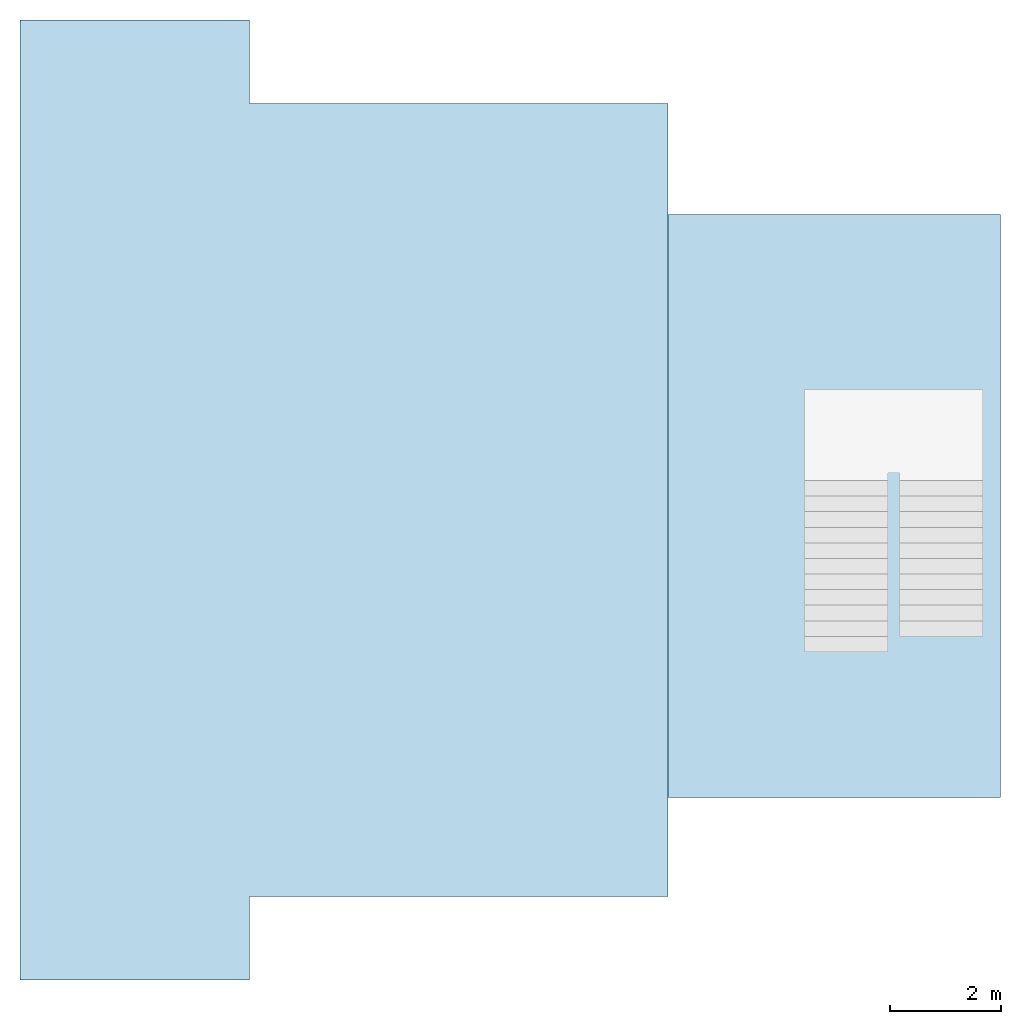
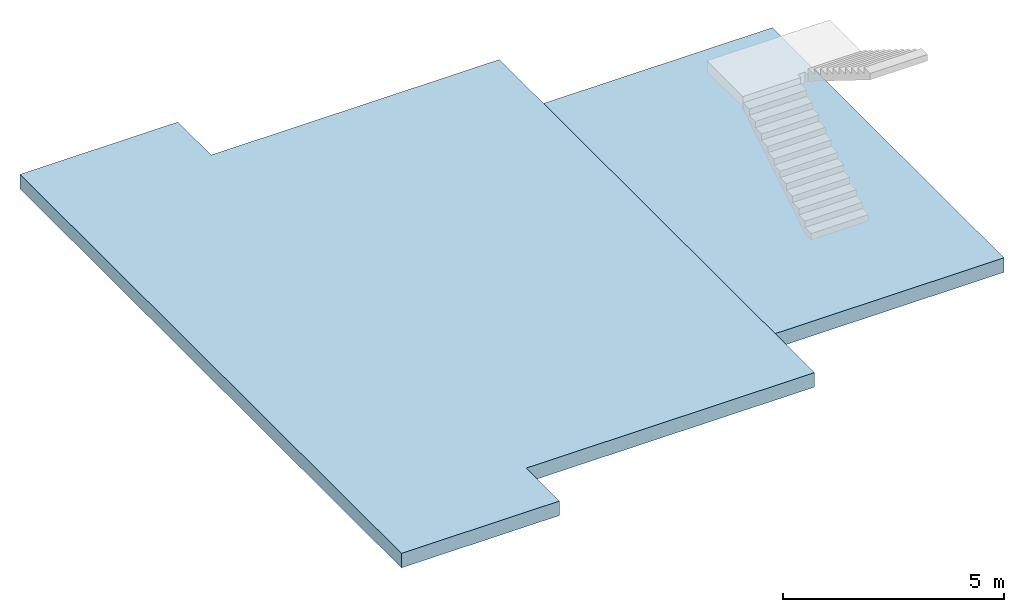
# One storey, part 1 of 2: 2 slabs.
"""IFC2X3 building model written with IfcOpenShell, lengths in millimetres."""

from ifc_helpers import new_model, entity, si_unit, converted_unit, derived_unit, direction, frame, origin, origin_2d_with_axis, place, context, subcontext, project, spatial, polyline, rectangle, outline, extrude, material, layer, layer_set, layer_usage, type_object, element, save


model = new_model("IFC2X3")

# Units and contexts
model_context = context("Model", 3, precision=0.01, world=origin(), true_north=direction((6.12303176911189e-17, 1.0)))
body_context = subcontext(model_context, "Body", "Model", "MODEL_VIEW")
ifc_project = project(units=[si_unit("LENGTHUNIT", "METRE", prefix="MILLI"), si_unit("AREAUNIT", "SQUARE_METRE"), si_unit("VOLUMEUNIT", "CUBIC_METRE"), converted_unit("PLANEANGLEUNIT", "DEGREE", entity("IfcRatioMeasure", 0.0174532925199433), si_unit("PLANEANGLEUNIT", "RADIAN"), dimensions=[0, 0, 0, 0, 0, 0, 0]), si_unit("MASSUNIT", "GRAM", prefix="KILO"), derived_unit("MASSDENSITYUNIT", [(si_unit("MASSUNIT", "GRAM", prefix="KILO"), 1), (si_unit("LENGTHUNIT", "METRE"), -3)]), si_unit("TIMEUNIT", "SECOND"), si_unit("FREQUENCYUNIT", "HERTZ"), si_unit("THERMODYNAMICTEMPERATUREUNIT", "DEGREE_CELSIUS"), derived_unit("THERMALTRANSMITTANCEUNIT", [(si_unit("MASSUNIT", "GRAM", prefix="KILO"), 1), (si_unit("THERMODYNAMICTEMPERATUREUNIT", "KELVIN"), -1), (si_unit("TIMEUNIT", "SECOND"), -3)]), derived_unit("VOLUMETRICFLOWRATEUNIT", [(si_unit("LENGTHUNIT", "METRE"), 3), (si_unit("TIMEUNIT", "SECOND"), -1)]), si_unit("ELECTRICCURRENTUNIT", "AMPERE"), si_unit("ELECTRICVOLTAGEUNIT", "VOLT"), si_unit("POWERUNIT", "WATT"), si_unit("FORCEUNIT", "NEWTON", prefix="KILO"), si_unit("ILLUMINANCEUNIT", "LUX"), si_unit("LUMINOUSFLUXUNIT", "LUMEN"), si_unit("LUMINOUSINTENSITYUNIT", "CANDELA"), derived_unit("USERDEFINED", [(si_unit("MASSUNIT", "GRAM", prefix="KILO"), -1), (si_unit("LENGTHUNIT", "METRE"), -2), (si_unit("TIMEUNIT", "SECOND"), 3), (si_unit("LUMINOUSFLUXUNIT", "LUMEN"), 1)]), derived_unit("LINEARVELOCITYUNIT", [(si_unit("LENGTHUNIT", "METRE"), 1), (si_unit("TIMEUNIT", "SECOND"), -1)]), si_unit("PRESSUREUNIT", "PASCAL"), derived_unit("USERDEFINED", [(si_unit("LENGTHUNIT", "METRE"), -2), (si_unit("MASSUNIT", "GRAM", prefix="KILO"), 1), (si_unit("TIMEUNIT", "SECOND"), -2)])], contexts=[model_context])

# Site, building, storey
site_placement = place(None, origin())
site = spatial("IfcSite", under=ifc_project, at=site_placement, CompositionType="ELEMENT")
building_placement = place(site_placement, origin())
building = spatial("IfcBuilding", under=site, at=building_placement, CompositionType="ELEMENT")
storey_placement = place(building_placement, origin())
storey = spatial("IfcBuildingStorey", under=building, at=storey_placement, Name="00 Ground level", CompositionType="ELEMENT", Elevation=0.0)

# Slabs
ifc_material_1 = material(Name="02_C40/50")
ifc_layer_1 = layer(ifc_material_1, 200.0)
ifc_material_2 = material(Name="01")
ifc_layer_2 = layer(ifc_material_2, 200.0)
ifc_layer_set = layer_set([ifc_layer_1, ifc_layer_2], Name="Floor")
ifc_layer_usage_1 = layer_usage(ifc_layer_set, "AXIS3", "POSITIVE", 0.0)
slab_type_1 = type_object("IfcSlabType", Name="Floor", PredefinedType="FLOOR", material=ifc_layer_set)
slab_1_placement = place(storey_placement, origin())
element("IfcSlab", 1, at=slab_1_placement, inside=storey, type_object=slab_type_1, material=ifc_layer_usage_1, Name="Floor", ObjectType="Floor", PredefinedType="FLOOR", context=body_context, shape_type="SweptSolid", body=[
    extrude(outline(polyline([(-8620.0, -4970.0), (8620.0, -4970.0), (8620.0, -850.0), (7120.0, -850.0), (7120.0, 6670.0), (-7120.0, 6670.0), (-7120.0, -850.0), (-8620.0, -850.0), (-8620.0, -4970.0)])), frame((22143.4900708518, -68831.2395851399, -140.0), z_axis=(0.0, 0.0, -1.0), x_axis=(0.0, 1.0, 0.0)), (0.0, 0.0, 1.0), 400.0),
])
ifc_layer_usage_2 = layer_usage(ifc_layer_set, "AXIS3", "POSITIVE", 0.0)
slab_type_2 = type_object("IfcSlabType", Name="Floor", PredefinedType="FLOOR", material=ifc_layer_set)
slab_2_placement = place(storey_placement, origin())
element("IfcSlab", 2, at=slab_2_placement, inside=storey, type_object=slab_type_2, material=ifc_layer_usage_2, Name="Floor", ObjectType="Floor", PredefinedType="FLOOR", context=body_context, shape_type="SweptSolid", body=[
    extrude(rectangle(XDim=10470.0, YDim=5969.99999999994, at=origin_2d_with_axis()), frame((31798.4900708518, -68940.8241905963, -140.0), z_axis=(0.0, 0.0, -1.0), x_axis=(0.0, 1.0, 0.0)), (0.0, 0.0, 1.0), 400.0),
])

save(model, "model.ifc")
